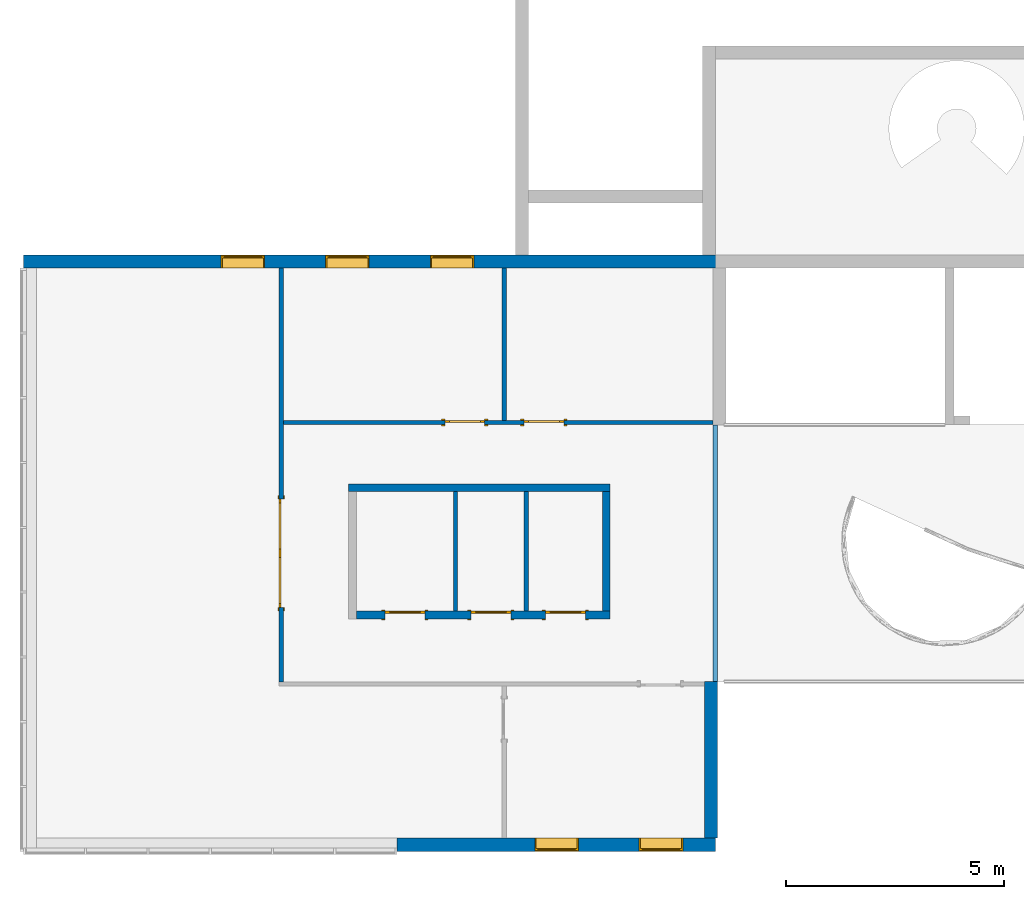
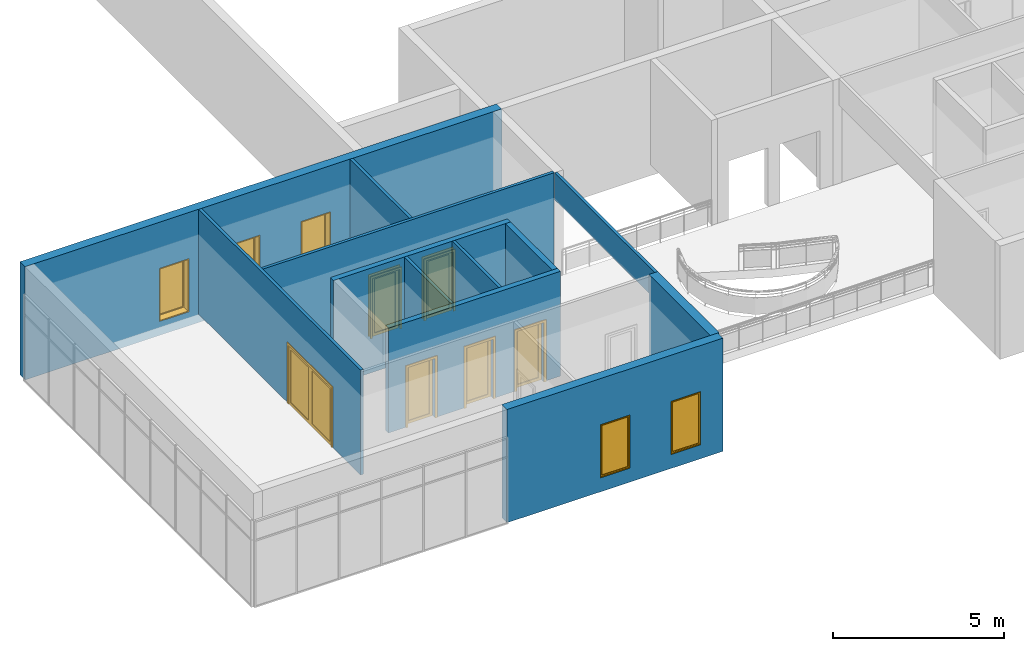
# One storey, part 10 of 13: 12 walls, 6 doors, 5 windows, 12 openings.
"""IFC2X3 building model written with IfcOpenShell, lengths in millimetres."""

from ifc_helpers import new_model, entity, si_unit, converted_unit, derived_unit, direction, frame, frame_2d, origin, origin_2d_with_axis, place, context, subcontext, project, spatial, polyline, rectangle, outline, extrude, source, transform, mapped, material, material_list, layer, layer_set, layer_usage, type_object, type_shapes, element, fill, save


model = new_model("IFC2X3")

# Units and contexts
model_context = context("Model", 3, precision=0.01, world=origin(), true_north=direction((6.12303176911189e-17, 1.0)))
context_of_model = context(None, 3, precision=0.01, world=origin(), true_north=direction((6.12303176911189e-17, 1.0)))
body_context = subcontext(model_context, "Body", "Model", "MODEL_VIEW")
ifc_project = project(units=[si_unit("LENGTHUNIT", "METRE", prefix="MILLI"), si_unit("AREAUNIT", "SQUARE_METRE"), si_unit("VOLUMEUNIT", "CUBIC_METRE"), converted_unit("PLANEANGLEUNIT", "DEGREE", entity("IfcRatioMeasure", 0.0174532925199433), si_unit("PLANEANGLEUNIT", "RADIAN"), dimensions=[0, 0, 0, 0, 0, 0, 0]), si_unit("MASSUNIT", "GRAM", prefix="KILO"), si_unit("TIMEUNIT", "SECOND"), si_unit("FREQUENCYUNIT", "HERTZ"), si_unit("THERMODYNAMICTEMPERATUREUNIT", "DEGREE_CELSIUS"), derived_unit("THERMALTRANSMITTANCEUNIT", [(si_unit("MASSUNIT", "GRAM", prefix="KILO"), 1), (si_unit("THERMODYNAMICTEMPERATUREUNIT", "KELVIN"), -1), (si_unit("TIMEUNIT", "SECOND"), -3)]), derived_unit("VOLUMETRICFLOWRATEUNIT", [(si_unit("LENGTHUNIT", "METRE"), 3), (si_unit("TIMEUNIT", "SECOND"), -1)]), si_unit("ELECTRICCURRENTUNIT", "AMPERE"), si_unit("ELECTRICVOLTAGEUNIT", "VOLT"), si_unit("POWERUNIT", "WATT"), si_unit("FORCEUNIT", "NEWTON", prefix="KILO"), si_unit("ILLUMINANCEUNIT", "LUX"), si_unit("LUMINOUSFLUXUNIT", "LUMEN"), si_unit("LUMINOUSINTENSITYUNIT", "CANDELA"), si_unit("PRESSUREUNIT", "PASCAL")], contexts=[model_context, context_of_model])

# Site, building, storey
site_placement = place(None, origin())
site = spatial("IfcSite", under=ifc_project, at=site_placement, CompositionType="ELEMENT")
building_placement = place(site_placement, origin())
building = spatial("IfcBuilding", under=site, at=building_placement, CompositionType="ELEMENT")
storey_placement = place(building_placement, frame((0.0, 0.0, 3750.0)))
storey = spatial("IfcBuildingStorey", under=building, at=storey_placement, Name="02. 2 etg.", CompositionType="ELEMENT", Elevation=3750.00000000068)

# Wall, openings, windows
ifc_material_1 = material(Name="Brick, Engineering, Soldier Course")
ifc_layer_1 = layer(ifc_material_1, 300.0)
ifc_layer_set_1 = layer_set([ifc_layer_1], Name="Basic Wall:Generic - 300mm")
ifc_layer_usage_1 = layer_usage(ifc_layer_set_1, "AXIS2", "POSITIVE", -150.0)
wall_type_1 = type_object("IfcWallType", Name="Basic Wall:Generic - 300mm", PredefinedType="STANDARD", material=ifc_layer_set_1)
wall_1_placement = place(storey_placement, frame((15890.0, 90.0, -300.0), z_axis=(0.0, 0.0, 1.0), x_axis=(-1.0, 0.0, 0.0)))
wall_1 = element("IfcWallStandardCase", 1, at=wall_1_placement, inside=storey, type_object=wall_type_1, material=ifc_layer_usage_1, Name="Basic Wall:Generic - 300mm", ObjectType="Basic Wall:Generic - 300mm:6291", context=body_context, shape_type="SweptSolid", body=[
    extrude(rectangle(XDim=16130.0, YDim=300.0, at=frame_2d((8065.00000000001, -1.4210854715202e-14), x_axis=(-1.0, 0.0))), origin(), (0.0, 0.0, 1.0), 4050.0),
])
opening_1_placement = place(wall_1_placement, frame((11590.0, 150.0, 500.0)))
opening_1 = element("IfcOpeningElement", 2, at=opening_1_placement, cuts=wall_1, Name="M_Fixed:0406 x 0610mm:1", ObjectType="Opening", context=body_context, shape_type="SweptSolid", body=[
    extrude(rectangle(XDim=1900.0, YDim=1000.0, at=frame_2d((949.999999999998, 500.0), x_axis=(1.0, 0.0))), frame((0.0, 0.0, 0.0), z_axis=(0.0, -1.0, 0.0), x_axis=(0.0, 0.0, 1.0)), (0.0, 0.0, 1.0), 300.0),
])
opening_2_placement = place(wall_1_placement, frame((9190.0, 150.0, 500.0)))
opening_2 = element("IfcOpeningElement", 3, at=opening_2_placement, cuts=wall_1, Name="M_Fixed:0406 x 0610mm:1", ObjectType="Opening", context=body_context, shape_type="SweptSolid", body=[
    extrude(rectangle(XDim=1900.0, YDim=1000.0, at=frame_2d((949.999999999998, 500.0), x_axis=(1.0, 0.0))), frame((0.0, 0.0, 0.0), z_axis=(0.0, -1.0, 0.0), x_axis=(0.0, 0.0, 1.0)), (0.0, 0.0, 1.0), 300.0),
])
opening_3_placement = place(wall_1_placement, frame((6790.0, 150.0, 500.0)))
opening_3 = element("IfcOpeningElement", 4, at=opening_3_placement, cuts=wall_1, Name="M_Fixed:0406 x 0610mm:1", ObjectType="Opening", context=body_context, shape_type="SweptSolid", body=[
    extrude(rectangle(XDim=1900.0, YDim=1000.0, at=frame_2d((949.999999999998, 500.0), x_axis=(1.0, 0.0))), frame((0.0, 0.0, 0.0), z_axis=(0.0, -1.0, 0.0), x_axis=(0.0, 0.0, 1.0)), (0.0, 0.0, 1.0), 300.0),
])
ifc_material_2 = material(Name="Glass")
ifc_material_3 = material(Name="Stainless Steel")
ifc_material_list_1 = material_list([ifc_material_2, ifc_material_3])
ifc_material_list_2 = material_list([ifc_material_2, ifc_material_3])
window_style = type_object("IfcWindowStyle", Name="0406 x 0610mm", ConstructionType="NOTDEFINED", OperationType="NOTDEFINED", ParameterTakesPrecedence=False, Sizeable=False, material=ifc_material_list_2)
shared_shape_1 = source(origin(), body_context, "Body", "SweptSolid", [
    extrude(rectangle(XDim=12.0, YDim=873.999999999997, at=frame_2d((8.43769498715119e-15, 0.0), x_axis=(1.0, 0.0))), frame((500.0, 259.0, 63.0), z_axis=(0.0, 0.0, 1.0), x_axis=(0.0, -1.0, 0.0)), (0.0, 0.0, 1.0), 1774.00000000001),
    extrude(outline(polyline([(-481.0, -931.0), (481.0, -931.0), (481.0, 931.0), (-481.0, 931.0), (-481.0, -931.0)]), holes=[polyline([(-437.0, -887.0), (-437.0, 887.0), (437.0, 887.0), (437.0, -887.0), (-437.0, -887.0)])]), frame((500.0, 237.0, 950.0), z_axis=(0.0, 1.0, 0.0), x_axis=(1.0, 0.0, 0.0)), (0.0, 0.0, 1.0), 44.0000000000274),
    extrude(outline(polyline([(-500.0, -950.0), (500.0, -950.0), (500.0, 950.0), (-500.0, 950.0), (-500.0, -950.0)]), holes=[polyline([(-481.0, -931.0), (-481.0, 931.0), (481.0, 931.0), (481.0, -931.0), (-481.0, -931.0)])]), frame((500.0, 237.0, 950.0), z_axis=(0.0, 1.0, 0.0), x_axis=(1.0, 0.0, 0.0)), (0.0, 0.0, 1.0), 63.0000000000274),
    extrude(outline(polyline([(-500.0, -950.0), (500.0, -950.0), (500.0, 950.0), (-500.0, 950.0), (-500.0, -950.0)]), holes=[polyline([(-468.0, -918.0), (-468.0, 918.0), (468.0, 918.0), (468.0, -918.0), (-468.0, -918.0)])]), frame((500.0, 0.0, 950.0), z_axis=(0.0, 1.0, 0.0), x_axis=(1.0, 0.0, 0.0)), (0.0, 0.0, 1.0), 236.999999999973),
])
type_shapes(window_style, [shared_shape_1])
window_1_placement = place(opening_1_placement, frame((0.0, 0.0, 0.0), z_axis=(0.0, 0.0, 1.0), x_axis=(-1.0, 0.0, 0.0)))
window_1 = element("IfcWindow", 5, at=window_1_placement, inside=storey, type_object=window_style, material=ifc_material_list_1, Name="M_Fixed:0406 x 0610mm", ObjectType="0406 x 0610mm", OverallHeight=1900.0, OverallWidth=1000.0, context=body_context, shape_type="MappedRepresentation", body=[
    mapped(shared_shape_1, transform((0.0, 0.0, 0.0), scale=1.0)),
])
fill(opening_1, window_1)
ifc_material_list_3 = material_list([ifc_material_2, ifc_material_3])
window_2_placement = place(opening_2_placement, frame((0.0, 0.0, 0.0), z_axis=(0.0, 0.0, 1.0), x_axis=(-1.0, 0.0, 0.0)))
window_2 = element("IfcWindow", 6, at=window_2_placement, inside=storey, type_object=window_style, material=ifc_material_list_3, Name="M_Fixed:0406 x 0610mm", ObjectType="0406 x 0610mm", OverallHeight=1900.0, OverallWidth=1000.0, context=body_context, shape_type="MappedRepresentation", body=[
    mapped(shared_shape_1, transform((0.0, 0.0, 0.0), scale=1.0)),
])
fill(opening_2, window_2)
ifc_material_list_4 = material_list([ifc_material_2, ifc_material_3])
window_3_placement = place(opening_3_placement, frame((0.0, 0.0, 0.0), z_axis=(0.0, 0.0, 1.0), x_axis=(-1.0, 0.0, 0.0)))
window_3 = element("IfcWindow", 7, at=window_3_placement, inside=storey, type_object=window_style, material=ifc_material_list_4, Name="M_Fixed:0406 x 0610mm", ObjectType="0406 x 0610mm", OverallHeight=1900.0, OverallWidth=1000.0, context=body_context, shape_type="MappedRepresentation", body=[
    mapped(shared_shape_1, transform((0.0, 0.0, 0.0), scale=1.0)),
])
fill(opening_3, window_3)

# Wall
ifc_layer_usage_2 = layer_usage(ifc_layer_set_1, "AXIS2", "POSITIVE", -150.0)
wall_2_placement = place(storey_placement, frame((15544.0, -13140.0, -300.0), z_axis=(0.0, 0.0, 1.0), x_axis=(0.0, 1.0, 0.0)))
element("IfcWallStandardCase", 8, at=wall_2_placement, inside=storey, type_object=wall_type_1, material=ifc_layer_usage_2, Name="Basic Wall:Generic - 300mm", ObjectType="Basic Wall:Generic - 300mm:6291", context=body_context, shape_type="SweptSolid", body=[
    extrude(rectangle(XDim=3600.00000000008, YDim=300.000000000001, at=frame_2d((1800.00000000004, -9.9475983006414e-14), x_axis=(-1.0, 0.0))), origin(), (0.0, 0.0, 1.0), 4050.0),
])

# Wall, openings, windows
ifc_layer_usage_3 = layer_usage(ifc_layer_set_1, "AXIS2", "POSITIVE", -150.0)
wall_3_placement = place(storey_placement, frame((8340.0, -13290.0, -300.0)))
wall_3 = element("IfcWallStandardCase", 9, at=wall_3_placement, inside=storey, type_object=wall_type_1, material=ifc_layer_usage_3, Name="Basic Wall:Generic - 300mm", ObjectType="Basic Wall:Generic - 300mm:6291", context=body_context, shape_type="SweptSolid", body=[
    extrude(rectangle(XDim=7304.00000000001, YDim=300.000000000001, at=frame_2d((3652.00000000001, -9.9475983006414e-14), x_axis=(-1.0, 0.0))), origin(), (0.0, 0.0, 1.0), 4050.0),
])
opening_4_placement = place(wall_3_placement, frame((7304.0, -302.400000000025, -3450.0)))
element("IfcOpeningElement", 10, at=opening_4_placement, cuts=wall_3, Name="Basic Wall:Generic - 300mm", ObjectType="Opening", context=body_context, shape_type="SweptSolid", body=[
    extrude(rectangle(XDim=7499.99999999993, YDim=9374.23571234945, at=origin_2d_with_axis()), frame((4687.11785617472, 0.0, 3750.0), z_axis=(0.0, 1.0, 0.0), x_axis=(0.0, 0.0, 1.0)), (0.0, 0.0, 1.0), 604.799999999999),
])
opening_5_placement = place(wall_3_placement, frame((4160.0, 150.0, 500.0)))
opening_5 = element("IfcOpeningElement", 11, at=opening_5_placement, cuts=wall_3, Name="M_Fixed:0406 x 0610mm:1", ObjectType="Opening", context=body_context, shape_type="SweptSolid", body=[
    extrude(rectangle(XDim=1900.0, YDim=1000.0, at=frame_2d((949.999999999998, 500.0), x_axis=(1.0, 0.0))), frame((0.0, 0.0, 0.0), z_axis=(0.0, -1.0, 0.0), x_axis=(0.0, 0.0, 1.0)), (0.0, 0.0, 1.0), 300.0),
])
opening_6_placement = place(wall_3_placement, frame((6555.0, 150.0, 500.0)))
opening_6 = element("IfcOpeningElement", 12, at=opening_6_placement, cuts=wall_3, Name="M_Fixed:0406 x 0610mm:1", ObjectType="Opening", context=body_context, shape_type="SweptSolid", body=[
    extrude(rectangle(XDim=1900.0, YDim=1000.0, at=frame_2d((949.999999999998, 500.0), x_axis=(1.0, 0.0))), frame((0.0, 0.0, 0.0), z_axis=(0.0, -1.0, 0.0), x_axis=(0.0, 0.0, 1.0)), (0.0, 0.0, 1.0), 300.0),
])
ifc_material_list_5 = material_list([ifc_material_2, ifc_material_3])
window_4_placement = place(opening_5_placement, frame((0.0, 0.0, 0.0), z_axis=(0.0, 0.0, 1.0), x_axis=(-1.0, 0.0, 0.0)))
window_4 = element("IfcWindow", 13, at=window_4_placement, inside=storey, type_object=window_style, material=ifc_material_list_5, Name="M_Fixed:0406 x 0610mm", ObjectType="0406 x 0610mm", OverallHeight=1900.0, OverallWidth=1000.0, context=body_context, shape_type="MappedRepresentation", body=[
    mapped(shared_shape_1, transform((0.0, 0.0, 0.0), scale=1.0)),
])
fill(opening_5, window_4)
ifc_material_list_6 = material_list([ifc_material_2, ifc_material_3])
window_5_placement = place(opening_6_placement, frame((0.0, 0.0, 0.0), z_axis=(0.0, 0.0, 1.0), x_axis=(-1.0, 0.0, 0.0)))
window_5 = element("IfcWindow", 14, at=window_5_placement, inside=storey, type_object=window_style, material=ifc_material_list_6, Name="M_Fixed:0406 x 0610mm", ObjectType="0406 x 0610mm", OverallHeight=1900.0, OverallWidth=1000.0, context=body_context, shape_type="MappedRepresentation", body=[
    mapped(shared_shape_1, transform((0.0, 0.0, 0.0), scale=1.0)),
])
fill(opening_6, window_5)

# Wall, opening, door
ifc_material_4 = material(Name="Steel, Paint Finish, Ivory, Matte")
ifc_layer_2 = layer(ifc_material_4, 100.0)
ifc_layer_set_2 = layer_set([ifc_layer_2], Name="Basic Wall:_100mm")
ifc_layer_usage_4 = layer_usage(ifc_layer_set_2, "AXIS2", "NEGATIVE", 50.0)
wall_type_2 = type_object("IfcWallType", Name="Basic Wall:_100mm", PredefinedType="STANDARD", material=ifc_layer_set_2)
wall_4_placement = place(storey_placement, frame((5679.11785617473, -9550.0, 0.0), z_axis=(0.0, 0.0, 1.0), x_axis=(0.0, 1.0, 0.0)))
wall_4 = element("IfcWallStandardCase", 15, at=wall_4_placement, inside=storey, type_object=wall_type_2, material=ifc_layer_usage_4, Name="Basic Wall:_100mm", ObjectType="Basic Wall:_100mm", context=body_context, shape_type="SweptSolid", body=[
    extrude(rectangle(XDim=9490.00000000001, YDim=100.000000000001, at=frame_2d((4745.00000000001, 0.0), x_axis=(-1.0, 0.0))), origin(), (0.0, 0.0, 1.0), 3750.0),
])
opening_7_placement = place(wall_4_placement, frame((1700.0, -50.0, 0.0)))
opening_7 = element("IfcOpeningElement", 16, at=opening_7_placement, cuts=wall_4, Name="M_Double-Glass 1:2500x2100:1", ObjectType="Opening", context=body_context, shape_type="SweptSolid", body=[
    extrude(rectangle(XDim=2500.0, YDim=2100.0, at=frame_2d((1050.0, 1250.0), x_axis=(0.0, 1.0))), frame((0.0, 0.0, 0.0), z_axis=(0.0, 1.0, 0.0), x_axis=(0.0, 0.0, 1.0)), (0.0, 0.0, 1.0), 100.0),
])
ifc_material_5 = material(Name="Metal - Stainless Steel,Polished")
ifc_material_6 = material(Name="Steel, Chrome Plated")
ifc_material_list_7 = material_list([ifc_material_5, ifc_material_2, ifc_material_6])
ifc_material_list_8 = material_list([ifc_material_5, ifc_material_2, ifc_material_6])
door_style_1 = type_object("IfcDoorStyle", Name="2500x2100", ConstructionType="NOTDEFINED", OperationType="DOUBLE_DOOR_SINGLE_SWING", ParameterTakesPrecedence=False, Sizeable=False, material=ifc_material_list_8)
shared_shape_2 = source(origin(), body_context, "Body", "SweptSolid", [
    extrude(outline(polyline([(-1326.0, -1069.0), (-1250.0, -1069.0), (-1250.0, 1031.0), (1250.0, 1031.0), (1250.0, -1069.0), (1326.0, -1069.0), (1326.0, 1107.0), (-1326.0, 1107.0), (-1326.0, -1069.0)])), frame((1250.0, -25.0, 1069.0), z_axis=(0.0, 1.0, 0.0), x_axis=(-1.0, 0.0, 0.0)), (0.0, 0.0, 1.0), 25.0),
    extrude(outline(polyline([(-1250.0, -1031.0), (-1250.0, 1069.0), (-1326.0, 1069.0), (-1326.0, -1107.0), (1326.0, -1107.0), (1326.0, 1069.0), (1250.0, 1069.0), (1250.0, -1031.0), (-1250.0, -1031.0)])), frame((1250.0, 100.0, 1069.0), z_axis=(0.0, -1.0, 0.0), x_axis=(-1.0, 0.0, 0.0)), (0.0, 0.0, -1.0), 24.999999999997),
    extrude(rectangle(XDim=7.14374999999973, YDim=1046.8, at=frame_2d((0.0, -5.6843418860808e-14), x_axis=(1.0, 0.0))), frame((1875.0, 78.1718749999958, 102.0), z_axis=(0.0, 0.0, 1.0), x_axis=(0.0, 1.0, 0.0)), (0.0, 0.0, 1.0), 1896.0),
    extrude(rectangle(XDim=7.14374999999973, YDim=1046.8, at=frame_2d((0.0, -5.6843418860808e-14), x_axis=(1.0, 0.0))), frame((625.0, 78.1718749999958, 102.0), z_axis=(0.0, 0.0, 1.0), x_axis=(0.0, 1.0, 0.0)), (0.0, 0.0, 1.0), 1896.0),
    extrude(outline(polyline([(-1050.0, -1250.0), (1050.0, -1250.0), (1050.0, 1250.0), (-1050.0, 1250.0), (-1050.0, -1250.0)]), holes=[polyline([(-948.0, 101.600000000038), (-948.0, 1148.40000000004), (948.0, 1148.40000000004), (948.0, 101.600000000038), (-948.0, 101.600000000038)]), polyline([(-948.0, -1148.39999999996), (-948.0, -101.599999999961), (948.0, -101.599999999961), (948.0, -1148.39999999996), (-948.0, -1148.39999999996)])]), frame((1250.0, 49.0, 1050.0), z_axis=(0.0, 1.0, 0.0), x_axis=(0.0, 0.0, -1.0)), (0.0, 0.0, 1.0), 51.0),
])
type_shapes(door_style_1, [shared_shape_2])
door_1_placement = place(opening_7_placement, origin())
door_1 = element("IfcDoor", 17, at=door_1_placement, inside=storey, type_object=door_style_1, material=ifc_material_list_7, Name="M_Double-Glass 1:2500x2100", ObjectType="2500x2100", OverallHeight=2100.0, OverallWidth=2500.0, context=body_context, shape_type="MappedRepresentation", body=[
    mapped(shared_shape_2, transform((0.0, 0.0, 0.0), scale=1.0)),
])
fill(opening_7, door_1)

# Wall, openings, doors
ifc_layer_usage_5 = layer_usage(ifc_layer_set_2, "AXIS2", "NEGATIVE", 50.0)
wall_5_placement = place(storey_placement, frame((15590.0, -3600.0, 0.0), z_axis=(0.0, 0.0, 1.0), x_axis=(-1.0, 0.0, 0.0)))
wall_5 = element("IfcWallStandardCase", 18, at=wall_5_placement, inside=storey, type_object=wall_type_2, material=ifc_layer_usage_5, Name="Basic Wall:_100mm", ObjectType="Basic Wall:_100mm", context=body_context, shape_type="SweptSolid", body=[
    extrude(rectangle(XDim=9860.88214382529, YDim=100.0, at=frame_2d((4930.44107191265, 3.5527136788005e-14), x_axis=(-1.0, 0.0))), origin(), (0.0, 0.0, 1.0), 3750.0),
])
opening_8_placement = place(wall_5_placement, frame((6155.0, 50.0, 0.0)))
opening_8 = element("IfcOpeningElement", 19, at=opening_8_placement, cuts=wall_5, Name="M_Single-Glass 1:0915 x 2134mm:1", ObjectType="Opening", context=body_context, shape_type="SweptSolid", body=[
    extrude(rectangle(XDim=914.999999999999, YDim=2134.0, at=frame_2d((1067.0, 457.5), x_axis=(0.0, 1.0))), frame((0.0, 0.0, 0.0), z_axis=(0.0, -1.0, 0.0), x_axis=(0.0, 0.0, 1.0)), (0.0, 0.0, 1.0), 100.0),
])
opening_9_placement = place(wall_5_placement, frame((4340.0, 50.0, 0.0)))
opening_9 = element("IfcOpeningElement", 20, at=opening_9_placement, cuts=wall_5, Name="M_Single-Glass 1:0915 x 2134mm:1", ObjectType="Opening", context=body_context, shape_type="SweptSolid", body=[
    extrude(rectangle(XDim=914.999999999999, YDim=2134.0, at=frame_2d((1067.0, 457.5), x_axis=(0.0, -1.0))), frame((0.0, 0.0, 0.0), z_axis=(0.0, -1.0, 0.0), x_axis=(0.0, 0.0, 1.0)), (0.0, 0.0, 1.0), 100.0),
])
ifc_material_list_9 = material_list([ifc_material_3, ifc_material_2])
ifc_material_list_10 = material_list([ifc_material_3, ifc_material_2])
door_style_2 = type_object("IfcDoorStyle", Name="0915 x 2134mm", ConstructionType="NOTDEFINED", OperationType="SINGLE_SWING_RIGHT", ParameterTakesPrecedence=False, Sizeable=False, material=ifc_material_list_10)
shared_shape_3 = source(origin(), body_context, "Body", "SweptSolid", [
    extrude(outline(polyline([(-457.500000000003, -1048.0), (-457.500000000003, 1086.0), (-533.499999999999, 1086.0), (-533.499999999999, -1124.0), (533.500000000001, -1124.0), (533.500000000001, 1086.0), (457.500000000001, 1086.0), (457.500000000001, -1048.0), (-457.500000000003, -1048.0)])), frame((457.500000000001, -25.0, 1086.0), z_axis=(0.0, -1.0, 0.0), x_axis=(-1.0, 0.0, 0.0)), (0.0, 0.0, -1.0), 25.0),
    extrude(outline(polyline([(-457.500000000001, -1048.0), (-457.500000000001, 1086.0), (-533.499999999997, 1086.0), (-533.499999999997, -1124.0), (533.499999999999, -1124.0), (533.499999999999, 1086.0), (457.499999999999, 1086.0), (457.499999999999, -1048.0), (-457.500000000001, -1048.0)])), frame((457.499999999999, 100.0, 1086.0), z_axis=(0.0, -1.0, 0.0), x_axis=(-1.0, 0.0, 0.0)), (0.0, 0.0, -1.0), 25.0000000000156),
    extrude(rectangle(XDim=6.35, YDim=711.0, at=frame_2d((-4.21884749357559e-15, 0.0), x_axis=(1.0, 0.0))), frame((457.5, 74.6000000000039, 102.0), z_axis=(0.0, 0.0, 1.0), x_axis=(0.0, 1.0, 0.0)), (0.0, 0.0, 1.0), 1930.0),
    extrude(outline(polyline([(-1067.0, -457.499999999998), (1067.0, -457.499999999998), (1067.0, 457.499999999998), (-1067.0, 457.499999999998), (-1067.0, -457.499999999998)]), holes=[polyline([(-965.0, 355.499999999998), (965.0, 355.499999999998), (965.0, -355.500000000002), (-965.0, -355.500000000002), (-965.0, 355.499999999998)])]), frame((457.499999999998, 49.0, 1067.0), z_axis=(0.0, 1.0, 0.0), x_axis=(0.0, 0.0, -1.0)), (0.0, 0.0, 1.0), 51.0),
])
type_shapes(door_style_2, [shared_shape_3])
door_2_placement = place(opening_8_placement, frame((0.0, 0.0, 0.0), z_axis=(0.0, 0.0, 1.0), x_axis=(-1.0, 0.0, 0.0)))
door_2 = element("IfcDoor", 21, at=door_2_placement, inside=storey, type_object=door_style_2, material=ifc_material_list_9, Name="M_Single-Glass 1:0915 x 2134mm", ObjectType="0915 x 2134mm", OverallHeight=2134.0, OverallWidth=915.0, context=body_context, shape_type="MappedRepresentation", body=[
    mapped(shared_shape_3, transform((0.0, 0.0, 0.0), scale=1.0)),
])
fill(opening_8, door_2)
ifc_material_list_11 = material_list([ifc_material_3, ifc_material_2])
ifc_material_list_12 = material_list([ifc_material_3, ifc_material_2])
door_style_3 = type_object("IfcDoorStyle", Name="0915 x 2134mm", ConstructionType="NOTDEFINED", OperationType="SINGLE_SWING_LEFT", ParameterTakesPrecedence=False, Sizeable=False, material=ifc_material_list_12)
shared_shape_4 = source(origin(), body_context, "Body", "SweptSolid", [
    extrude(outline(polyline([(-457.500000000003, -1048.0), (-457.500000000003, 1086.0), (-533.499999999999, 1086.0), (-533.499999999999, -1124.0), (533.500000000001, -1124.0), (533.500000000001, 1086.0), (457.500000000001, 1086.0), (457.500000000001, -1048.0), (-457.500000000003, -1048.0)])), frame((457.499999999999, 0.0, 1086.0), z_axis=(0.0, 1.0, 0.0), x_axis=(1.0, 0.0, 0.0)), (0.0, 0.0, -1.0), 25.0),
    extrude(outline(polyline([(-457.500000000001, -1048.0), (-457.500000000001, 1086.0), (-533.499999999997, 1086.0), (-533.499999999997, -1124.0), (533.499999999999, -1124.0), (533.499999999999, 1086.0), (457.499999999999, 1086.0), (457.499999999999, -1048.0), (-457.500000000001, -1048.0)])), frame((457.500000000001, 125.0, 1086.0), z_axis=(0.0, 1.0, 0.0), x_axis=(1.0, 0.0, 0.0)), (0.0, 0.0, -1.0), 25.0000000000156),
    extrude(rectangle(XDim=711.0, YDim=6.35, at=origin_2d_with_axis()), frame((457.5, 74.6000000000257, 102.0)), (0.0, 0.0, 1.0), 1930.0),
    extrude(outline(polyline([(-1067.0, -457.499999999998), (1067.0, -457.499999999998), (1067.0, 457.499999999998), (-1067.0, 457.499999999998), (-1067.0, -457.499999999998)]), holes=[polyline([(-965.0, 355.499999999998), (965.0, 355.499999999998), (965.0, -355.500000000002), (-965.0, -355.500000000002), (-965.0, 355.499999999998)])]), frame((457.500000000002, 100.0, 1067.0), z_axis=(0.0, -1.0, 0.0), x_axis=(0.0, 0.0, -1.0)), (0.0, 0.0, 1.0), 51.0),
])
type_shapes(door_style_3, [shared_shape_4])
door_3_placement = place(opening_9_placement, frame((0.0, 0.0, 0.0), z_axis=(0.0, 0.0, 1.0), x_axis=(-1.0, 0.0, 0.0)))
door_3 = element("IfcDoor", 22, at=door_3_placement, inside=storey, type_object=door_style_3, material=ifc_material_list_11, Name="M_Single-Glass 1:0915 x 2134mm", ObjectType="0915 x 2134mm", OverallHeight=2134.0, OverallWidth=915.0, context=body_context, shape_type="MappedRepresentation", body=[
    mapped(shared_shape_4, transform((0.0, 0.0, 0.0), scale=1.0)),
])
fill(opening_9, door_3)

# Walls
ifc_layer_usage_6 = layer_usage(ifc_layer_set_2, "AXIS2", "NEGATIVE", 50.0)
wall_6_placement = place(storey_placement, frame((10800.0, -3550.0, 0.0), z_axis=(0.0, 0.0, 1.0), x_axis=(0.0, 1.0, 0.0)))
element("IfcWallStandardCase", 23, at=wall_6_placement, inside=storey, type_object=wall_type_2, material=ifc_layer_usage_6, Name="Basic Wall:_100mm", ObjectType="Basic Wall:_100mm", context=body_context, shape_type="SweptSolid", body=[
    extrude(rectangle(XDim=3490.00000000001, YDim=99.9999999999989, at=frame_2d((1745.00000000001, 0.0), x_axis=(-1.0, 0.0))), origin(), (0.0, 0.0, 1.0), 3750.0),
])
ifc_layer_usage_7 = layer_usage(ifc_layer_set_2, "AXIS2", "POSITIVE", -50.0)
wall_7_placement = place(storey_placement, frame((9679.11785617473, -5186.65631369453, 0.0), z_axis=(0.0, 0.0, 1.0), x_axis=(0.0, -1.0, 0.0)))
element("IfcWallStandardCase", 24, at=wall_7_placement, inside=storey, type_object=wall_type_2, material=ifc_layer_usage_7, Name="Basic Wall:_100mm", ObjectType="Basic Wall:_100mm", context=body_context, shape_type="SweptSolid", body=[
    extrude(rectangle(XDim=2740.0, YDim=99.9999999999989, at=frame_2d((1370.0, 0.0), x_axis=(-1.0, 0.0))), origin(), (0.0, 0.0, 1.0), 3750.0),
])
ifc_layer_usage_8 = layer_usage(ifc_layer_set_2, "AXIS2", "NEGATIVE", 50.0)
wall_8_placement = place(storey_placement, frame((11301.1178561747, -5186.65631369453, 0.0), z_axis=(0.0, 0.0, 1.0), x_axis=(0.0, -1.0, 0.0)))
element("IfcWallStandardCase", 25, at=wall_8_placement, inside=storey, type_object=wall_type_2, material=ifc_layer_usage_8, Name="Basic Wall:_100mm", ObjectType="Basic Wall:_100mm", context=body_context, shape_type="SweptSolid", body=[
    extrude(rectangle(XDim=2740.0, YDim=99.9999999999989, at=frame_2d((1370.0, 0.0), x_axis=(-1.0, 0.0))), origin(), (0.0, 0.0, 1.0), 3750.0),
])
ifc_layer_usage_9 = layer_usage(ifc_layer_set_2, "AXIS2", "NEGATIVE", 50.0)
wall_9_placement = place(storey_placement, frame((15640.0, -3660.0, 2800.0), z_axis=(0.0, 0.0, 1.0), x_axis=(0.0, -1.0, 0.0)))
element("IfcWallStandardCase", 26, at=wall_9_placement, inside=storey, type_object=wall_type_2, material=ifc_layer_usage_9, Name="Basic Wall:_100mm", ObjectType="Basic Wall:_100mm", context=body_context, shape_type="SweptSolid", body=[
    extrude(rectangle(XDim=5879.99999999997, YDim=99.9999999999989, at=frame_2d((2939.99999999998, 2.1316282072803e-14), x_axis=(-1.0, 0.0))), origin(), (0.0, 0.0, 1.0), 949.999999999925),
])
ifc_layer_3 = layer(ifc_material_4, 180.0)
ifc_layer_set_3 = layer_set([ifc_layer_3], Name="Basic Wall:_180mm")
ifc_layer_usage_10 = layer_usage(ifc_layer_set_3, "AXIS2", "NEGATIVE", 90.0)
wall_type_3 = type_object("IfcWallType", Name="Basic Wall:_180mm", PredefinedType="STANDARD", material=ifc_layer_set_3)
wall_10_placement = place(storey_placement, frame((7229.11785617473, -5096.65631369453, 0.0)))
element("IfcWallStandardCase", 27, at=wall_10_placement, inside=storey, type_object=wall_type_3, material=ifc_layer_usage_10, Name="Basic Wall:_180mm", ObjectType="Basic Wall:_180mm", context=body_context, shape_type="SweptSolid", body=[
    extrude(rectangle(XDim=6000.0, YDim=180.0, at=frame_2d((3000.0, 0.0), x_axis=(-1.0, 0.0))), origin(), (0.0, 0.0, 1.0), 3750.0),
])

# Wall, openings, doors
ifc_layer_usage_11 = layer_usage(ifc_layer_set_3, "AXIS2", "NEGATIVE", 90.0)
wall_11_placement = place(storey_placement, frame((13229.1178561747, -8016.65631369453, 0.0), z_axis=(0.0, 0.0, 1.0), x_axis=(-1.0, 0.0, 0.0)))
wall_11 = element("IfcWallStandardCase", 28, at=wall_11_placement, inside=storey, type_object=wall_type_3, material=ifc_layer_usage_11, Name="Basic Wall:_180mm", ObjectType="Basic Wall:_180mm", context=body_context, shape_type="SweptSolid", body=[
    extrude(rectangle(XDim=5820.0, YDim=180.0, at=frame_2d((2910.0, 0.0), x_axis=(-1.0, 0.0))), origin(), (0.0, 0.0, 1.0), 3750.0),
])
opening_10_placement = place(wall_11_placement, frame((5167.5, 90.0, 0.0)))
opening_10 = element("IfcOpeningElement", 29, at=opening_10_placement, cuts=wall_11, Name="M_Single-Glass 1:0915 x 2134mm:1", ObjectType="Opening", context=body_context, shape_type="SweptSolid", body=[
    extrude(rectangle(XDim=914.999999999999, YDim=2134.0, at=frame_2d((1067.0, 457.5), x_axis=(0.0, -1.0))), frame((0.0, 0.0, 0.0), z_axis=(0.0, -1.0, 0.0), x_axis=(0.0, 0.0, 1.0)), (0.0, 0.0, 1.0), 180.0),
])
opening_11_placement = place(wall_11_placement, frame((3196.5, 90.0, 0.0)))
opening_11 = element("IfcOpeningElement", 30, at=opening_11_placement, cuts=wall_11, Name="M_Single-Glass 1:0915 x 2134mm:1", ObjectType="Opening", context=body_context, shape_type="SweptSolid", body=[
    extrude(rectangle(XDim=914.999999999999, YDim=2134.0, at=frame_2d((1067.0, 457.5), x_axis=(0.0, -1.0))), frame((0.0, 0.0, 0.0), z_axis=(0.0, -1.0, 0.0), x_axis=(0.0, 0.0, 1.0)), (0.0, 0.0, 1.0), 180.0),
])
opening_12_placement = place(wall_11_placement, frame((1486.5, 90.0, 0.0)))
opening_12 = element("IfcOpeningElement", 31, at=opening_12_placement, cuts=wall_11, Name="M_Single-Glass 1:0915 x 2134mm:1", ObjectType="Opening", context=body_context, shape_type="SweptSolid", body=[
    extrude(rectangle(XDim=914.999999999999, YDim=2134.0, at=frame_2d((1067.0, 457.5), x_axis=(0.0, -1.0))), frame((0.0, 0.0, 0.0), z_axis=(0.0, -1.0, 0.0), x_axis=(0.0, 0.0, 1.0)), (0.0, 0.0, 1.0), 180.0),
])
ifc_material_list_13 = material_list([ifc_material_3, ifc_material_2])
ifc_material_list_14 = material_list([ifc_material_3, ifc_material_2])
door_style_4 = type_object("IfcDoorStyle", Name="0915 x 2134mm", ConstructionType="NOTDEFINED", OperationType="SINGLE_SWING_LEFT", ParameterTakesPrecedence=False, Sizeable=False, material=ifc_material_list_14)
shared_shape_5 = source(origin(), body_context, "Body", "SweptSolid", [
    extrude(outline(polyline([(-457.500000000003, -1048.0), (-457.500000000003, 1086.0), (-533.499999999999, 1086.0), (-533.499999999999, -1124.0), (533.500000000001, -1124.0), (533.500000000001, 1086.0), (457.500000000001, 1086.0), (457.500000000001, -1048.0), (-457.500000000003, -1048.0)])), frame((457.499999999999, 0.0, 1086.0), z_axis=(0.0, 1.0, 0.0), x_axis=(1.0, 0.0, 0.0)), (0.0, 0.0, -1.0), 25.0),
    extrude(outline(polyline([(-457.500000000001, -1048.0), (-457.500000000001, 1086.0), (-533.499999999997, 1086.0), (-533.499999999997, -1124.0), (533.499999999999, -1124.0), (533.499999999999, 1086.0), (457.499999999999, 1086.0), (457.499999999999, -1048.0), (-457.500000000001, -1048.0)])), frame((457.500000000001, 205.0, 1086.0), z_axis=(0.0, 1.0, 0.0), x_axis=(1.0, 0.0, 0.0)), (0.0, 0.0, -1.0), 25.0000000000156),
    extrude(rectangle(XDim=711.0, YDim=6.35, at=frame_2d((0.0, 4.21884749357559e-15), x_axis=(1.0, 0.0))), frame((457.5, 154.600000000026, 102.0)), (0.0, 0.0, 1.0), 1930.0),
    extrude(outline(polyline([(-1067.0, -457.499999999998), (1067.0, -457.499999999998), (1067.0, 457.499999999998), (-1067.0, 457.499999999998), (-1067.0, -457.499999999998)]), holes=[polyline([(-965.0, 355.499999999998), (965.0, 355.499999999998), (965.0, -355.500000000002), (-965.0, -355.500000000002), (-965.0, 355.499999999998)])]), frame((457.500000000002, 180.0, 1067.0), z_axis=(0.0, -1.0, 0.0), x_axis=(0.0, 0.0, -1.0)), (0.0, 0.0, 1.0), 51.0),
])
type_shapes(door_style_4, [shared_shape_5])
door_4_placement = place(opening_10_placement, frame((0.0, 0.0, 0.0), z_axis=(0.0, 0.0, 1.0), x_axis=(-1.0, 0.0, 0.0)))
door_4 = element("IfcDoor", 32, at=door_4_placement, inside=storey, type_object=door_style_4, material=ifc_material_list_13, Name="M_Single-Glass 1:0915 x 2134mm", ObjectType="0915 x 2134mm", OverallHeight=2134.0, OverallWidth=915.0, context=body_context, shape_type="MappedRepresentation", body=[
    mapped(shared_shape_5, transform((0.0, 0.0, 0.0), scale=1.0)),
])
fill(opening_10, door_4)
ifc_material_list_15 = material_list([ifc_material_3, ifc_material_2])
door_5_placement = place(opening_11_placement, frame((0.0, 0.0, 0.0), z_axis=(0.0, 0.0, 1.0), x_axis=(-1.0, 0.0, 0.0)))
door_5 = element("IfcDoor", 33, at=door_5_placement, inside=storey, type_object=door_style_4, material=ifc_material_list_15, Name="M_Single-Glass 1:0915 x 2134mm", ObjectType="0915 x 2134mm", OverallHeight=2134.0, OverallWidth=915.0, context=body_context, shape_type="MappedRepresentation", body=[
    mapped(shared_shape_5, transform((0.0, 0.0, 0.0), scale=1.0)),
])
fill(opening_11, door_5)
ifc_material_list_16 = material_list([ifc_material_3, ifc_material_2])
door_6_placement = place(opening_12_placement, frame((0.0, 0.0, 0.0), z_axis=(0.0, 0.0, 1.0), x_axis=(-1.0, 0.0, 0.0)))
door_6 = element("IfcDoor", 34, at=door_6_placement, inside=storey, type_object=door_style_4, material=ifc_material_list_16, Name="M_Single-Glass 1:0915 x 2134mm", ObjectType="0915 x 2134mm", OverallHeight=2134.0, OverallWidth=915.0, context=body_context, shape_type="MappedRepresentation", body=[
    mapped(shared_shape_5, transform((0.0, 0.0, 0.0), scale=1.0)),
])
fill(opening_12, door_6)

# Wall
ifc_layer_usage_12 = layer_usage(ifc_layer_set_3, "AXIS2", "NEGATIVE", 90.0)
wall_12_placement = place(storey_placement, frame((13139.1178561747, -5186.65631369453, 0.0), z_axis=(0.0, 0.0, 1.0), x_axis=(0.0, -1.0, 0.0)))
element("IfcWallStandardCase", 35, at=wall_12_placement, inside=storey, type_object=wall_type_3, material=ifc_layer_usage_12, Name="Basic Wall:_180mm", ObjectType="Basic Wall:_180mm", context=body_context, shape_type="SweptSolid", body=[
    extrude(rectangle(XDim=2740.0, YDim=179.999999999998, at=frame_2d((1370.0, 0.0), x_axis=(-1.0, 0.0))), origin(), (0.0, 0.0, 1.0), 3750.0),
])

save(model, "model.ifc")
